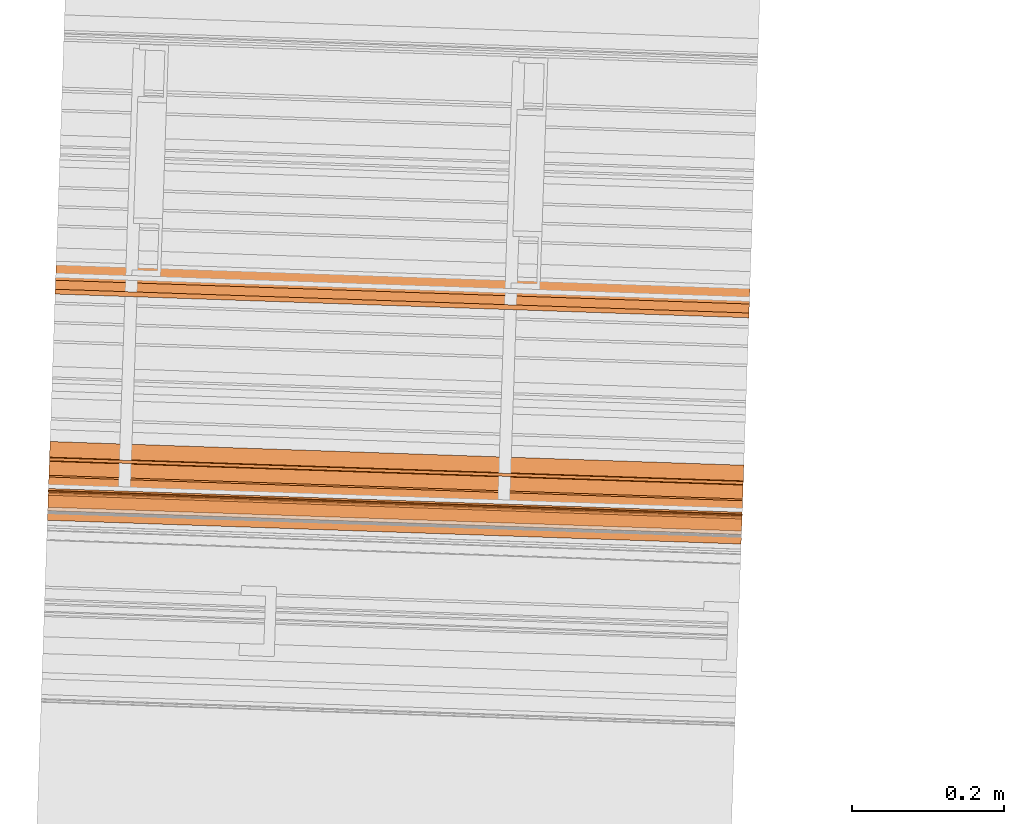
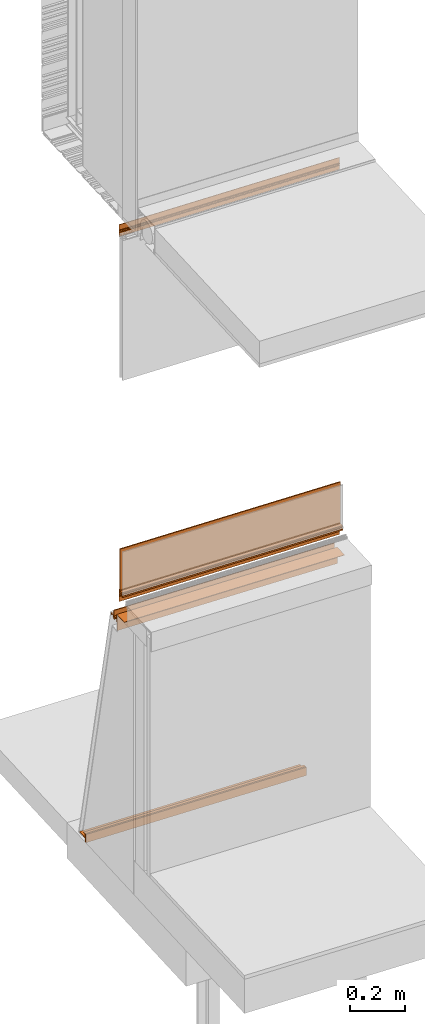
# One storey, part 11 of 36: 11 proxies.
"""IFC2X3 building model written with IfcOpenShell, lengths in feet."""

from ifc_helpers import new_model, entity, si_unit, converted_unit, derived_unit, direction, frame, frame_2d, origin, origin_2d_with_axis, place, context, subcontext, project, spatial, polyline, circle_curve, parameter, trimmed, segment, composite_curve, rectangle, outline, extrude, source, transform, mapped, material, type_object, type_shapes, element, save


model = new_model("IFC2X3")

# Units and contexts
model_context = context("Model", 3, precision=0.0001, world=origin(), true_north=direction((6.12303176911189e-17, 1.0)))
body_context = subcontext(model_context, "Body", "Model", "MODEL_VIEW")
ifc_project = project(units=[converted_unit("LENGTHUNIT", "FOOT", entity("IfcRatioMeasure", 0.3048), si_unit("LENGTHUNIT", "METRE"), dimensions=[1, 0, 0, 0, 0, 0, 0]), converted_unit("AREAUNIT", "SQUARE FOOT", entity("IfcRatioMeasure", 0.09290304), si_unit("AREAUNIT", "SQUARE_METRE"), dimensions=[2, 0, 0, 0, 0, 0, 0]), converted_unit("VOLUMEUNIT", "CUBIC FOOT", entity("IfcRatioMeasure", 0.028316846592), si_unit("VOLUMEUNIT", "CUBIC_METRE"), dimensions=[3, 0, 0, 0, 0, 0, 0]), converted_unit("PLANEANGLEUNIT", "DEGREE", entity("IfcRatioMeasure", 0.0174532925199433), si_unit("PLANEANGLEUNIT", "RADIAN"), dimensions=[0, 0, 0, 0, 0, 0, 0]), si_unit("MASSUNIT", "GRAM", prefix="KILO"), derived_unit("MASSDENSITYUNIT", [(si_unit("MASSUNIT", "GRAM", prefix="KILO"), 1), (si_unit("LENGTHUNIT", "METRE"), -3)]), si_unit("TIMEUNIT", "SECOND"), si_unit("FREQUENCYUNIT", "HERTZ"), si_unit("THERMODYNAMICTEMPERATUREUNIT", "DEGREE_CELSIUS"), derived_unit("THERMALTRANSMITTANCEUNIT", [(si_unit("MASSUNIT", "GRAM", prefix="KILO"), 1), (si_unit("THERMODYNAMICTEMPERATUREUNIT", "KELVIN"), -1), (si_unit("TIMEUNIT", "SECOND"), -3)]), derived_unit("VOLUMETRICFLOWRATEUNIT", [(si_unit("LENGTHUNIT", "METRE"), 3), (si_unit("TIMEUNIT", "SECOND"), -1)]), si_unit("ELECTRICCURRENTUNIT", "AMPERE"), si_unit("ELECTRICVOLTAGEUNIT", "VOLT"), si_unit("POWERUNIT", "WATT"), si_unit("FORCEUNIT", "NEWTON"), si_unit("ILLUMINANCEUNIT", "LUX"), si_unit("LUMINOUSFLUXUNIT", "LUMEN"), si_unit("LUMINOUSINTENSITYUNIT", "CANDELA"), derived_unit("USERDEFINED", [(si_unit("MASSUNIT", "GRAM", prefix="KILO"), -1), (si_unit("LENGTHUNIT", "METRE"), -2), (si_unit("TIMEUNIT", "SECOND"), 3), (si_unit("LUMINOUSFLUXUNIT", "LUMEN"), 1)]), derived_unit("LINEARVELOCITYUNIT", [(si_unit("LENGTHUNIT", "METRE"), 1), (si_unit("TIMEUNIT", "SECOND"), -1)]), si_unit("PRESSUREUNIT", "PASCAL"), derived_unit("USERDEFINED", [(si_unit("LENGTHUNIT", "METRE"), -2), (si_unit("MASSUNIT", "GRAM", prefix="KILO"), 1), (si_unit("TIMEUNIT", "SECOND"), -2)])], contexts=[model_context])

# Site, building, storey
site_placement = place(None, origin())
site = spatial("IfcSite", under=ifc_project, at=site_placement, CompositionType="ELEMENT")
building_placement = place(site_placement, origin())
building = spatial("IfcBuilding", under=site, at=building_placement, CompositionType="ELEMENT")
storey_placement = place(building_placement, origin())
storey = spatial("IfcBuildingStorey", under=building, at=storey_placement, Name="Level 1", CompositionType="ELEMENT", Elevation=0.0)

# Proxies
ifc_material_1 = material(Name="Window frame")
building_element_proxy_type_1 = type_object("IfcBuildingElementProxyType", Name="Window frame 016", PredefinedType="NOTDEFINED", material=ifc_material_1)
shared_shape_1 = source(origin(), body_context, "Body", "SweptSolid", [
    extrude(outline(composite_curve([segment(trimmed(circle_curve(frame_2d((0.0056011695834499, -0.0105069444443835), x_axis=(1.0, 0.0)), 0.00208333333333355), [parameter(359.999999999951)], [parameter(180.0)], True, "PARAMETER"), True, "CONTINUOUS"), segment(trimmed(circle_curve(frame_2d((0.00143450291648173, -0.0105069444443835), x_axis=(1.0, 0.0)), 0.00208333333333194), [parameter(270.0)], [parameter(0.0)], True, "PARAMETER"), False, "CONTINUOUS"), segment(polyline([(0.00143450291648124, -0.0125902777777149), (-0.00206549708348375, -0.0125902777778055)]), True, "CONTINUOUS"), segment(trimmed(circle_curve(frame_2d((-0.00206549708348375, -0.0105069444443835), x_axis=(1.0, 0.0)), 0.00208333333333249), [parameter(180.0)], [parameter(270.0)], True, "PARAMETER"), False, "CONTINUOUS"), segment(polyline([(-0.00414883041681443, -0.0105069444443835), (-0.00414883041661638, 0.00999305555562913)]), True, "CONTINUOUS"), segment(trimmed(circle_curve(frame_2d((-0.00206549708348454, 0.00999305555562913), x_axis=(1.0, 0.0)), 0.00208333333333313), [parameter(90.0000000000001)], [parameter(180.0)], True, "PARAMETER"), False, "CONTINUOUS"), segment(polyline([(-0.00206549708348405, 0.0120763888889623), (0.00143450291648094, 0.0120763888888593)]), True, "CONTINUOUS"), segment(trimmed(circle_curve(frame_2d((0.00143450291648094, 0.00999305555562913), x_axis=(1.0, 0.0)), 0.00208333333333237), [parameter(0.0)], [parameter(90.0000000000001)], True, "PARAMETER"), False, "CONTINUOUS"), segment(trimmed(circle_curve(frame_2d((0.00560116958344863, 0.00999305555562913), x_axis=(1.0, 0.0)), 0.00208333333333355), [parameter(180.0)], [parameter(0.0)], True, "PARAMETER"), True, "CONTINUOUS"), segment(polyline([(0.00768450291677979, 0.00999305555562913), (0.00768450291672444, 0.0146597222220013)]), True, "CONTINUOUS"), segment(trimmed(circle_curve(frame_2d((0.00510116958329547, 0.0146597222220013), x_axis=(1.0, 0.0)), 0.00258333333333234), [parameter(0.0)], [parameter(90.0000000000001)], True, "PARAMETER"), True, "CONTINUOUS"), segment(polyline([(0.00510116958329595, 0.0172430555553333), (-0.00231549708326447, 0.017243055555527)]), True, "CONTINUOUS"), segment(polyline([(-0.00231549708326447, 0.017243055555527), (-0.00231549708326215, 0.0755763888888605)]), True, "CONTINUOUS"), segment(polyline([(-0.00231549708326215, 0.0755763888888605), (-0.00748216374994208, 0.0755763888888605)]), True, "CONTINUOUS"), segment(polyline([(-0.00748216374994208, 0.0755763888888605), (-0.00748216374994111, 0.079743055555527)]), True, "CONTINUOUS"), segment(polyline([(-0.00748216374994111, 0.079743055555527), (-0.0108154970832782, 0.079743055555527)]), True, "CONTINUOUS"), segment(polyline([(-0.0108154970832782, 0.079743055555527), (-0.0108154970832785, -0.0973402777778052)]), True, "CONTINUOUS"), segment(polyline([(-0.0108154970832785, -0.0973402777778052), (-0.00306549708326241, -0.0973402777778052)]), True, "CONTINUOUS"), segment(polyline([(-0.00306549708326241, -0.0973402777778052), (-0.00414883041661713, -0.0921736111111375)]), True, "CONTINUOUS"), segment(polyline([(-0.00414883041661713, -0.0921736111111375), (-0.00414883041661802, -0.0192569444444715)]), True, "CONTINUOUS"), segment(polyline([(-0.00414883041661802, -0.0192569444444715), (0.00642309958338163, -0.0192569444444715)]), True, "CONTINUOUS"), segment(polyline([(0.00642309958338163, -0.0192569444444715), (0.0102678362500651, -0.0192569444444715)]), True, "CONTINUOUS"), segment(polyline([(0.0102678362500651, -0.0192569444444715), (0.010267836250067, -0.0125902777778055)]), True, "CONTINUOUS"), segment(polyline([(0.010267836250067, -0.0125902777778055), (0.00768450291678106, -0.0105069444443835)]), True, "CONTINUOUS")], self_intersect=False)), frame((109.718553820177, -50.5398433999572, 9.48804422127077), z_axis=(0.999414947916632, -0.0342017818365522, 0.0), x_axis=(-0.0342017818365522, -0.999414947916632, 0.0)), (0.0, 0.0, 1.0), 3.0),
])
type_shapes(building_element_proxy_type_1, [shared_shape_1])
proxy_1_placement = place(storey_placement, origin())
element("IfcBuildingElementProxy", 1, at=proxy_1_placement, inside=storey, type_object=building_element_proxy_type_1, material=ifc_material_1, Name="Window frame 016:Window frame 016", ObjectType="Window frame 016", context=body_context, shape_type="MappedRepresentation", body=[
    mapped(shared_shape_1, transform((0.0, 0.0, 0.0), scale=1.0)),
])
ifc_material_2 = material(Name="Clear glass")
building_element_proxy_type_2 = type_object("IfcBuildingElementProxyType", Name="Glass panel 007", PredefinedType="NOTDEFINED", material=ifc_material_2)
shared_shape_2 = source(origin(), body_context, "Body", "SweptSolid", [
    extrude(rectangle(XDim=3.0, YDim=0.0156250000000008, at=frame_2d((7.105427357601e-15, 2.42861286636753e-16), x_axis=(1.0, 0.0))), frame((111.217317225854, -50.6016369343463, 4.19540473523623), z_axis=(0.0, 0.0, 1.0), x_axis=(0.9994149479166, -0.0342017818375074, 0.0)), (0.0, 0.0, 1.0), 0.646205703051181),
])
type_shapes(building_element_proxy_type_2, [shared_shape_2])
proxy_2_placement = place(storey_placement, origin())
element("IfcBuildingElementProxy", 2, at=proxy_2_placement, inside=storey, type_object=building_element_proxy_type_2, material=ifc_material_2, Name="Glass panel 007:Glass panel 007", ObjectType="Glass panel 007", context=body_context, shape_type="MappedRepresentation", body=[
    mapped(shared_shape_2, transform((0.0, 0.0, 0.0), scale=1.0)),
])
building_element_proxy_type_3 = type_object("IfcBuildingElementProxyType", Name="Window frame part 042", PredefinedType="NOTDEFINED", material=ifc_material_1)
shared_shape_3 = source(origin(), body_context, "Body", "SweptSolid", [
    extrude(outline(polyline([(-0.00260416666666607, 0.0104166666666691), (0.0078125, 0.0104166666666691), (0.0078125, 0.0442500000000058), (-0.013020833333333, 0.0442500000000058), (-0.013020833333333, -0.0442499999999987), (0.0078125, -0.0442499999999987), (0.0078125, -0.010416666666662), (-0.00260416666666607, -0.010416666666662), (-0.00260416666666607, 0.0104166666666691)])), frame((109.717119585462, -50.5817533690172, 4.18238390190291), z_axis=(0.999414947916629, -0.0342017818366361, 0.0), x_axis=(0.0, 0.0, -1.0)), (0.0, 0.0, 1.0), 3.0),
])
type_shapes(building_element_proxy_type_3, [shared_shape_3])
proxy_3_placement = place(storey_placement, origin())
element("IfcBuildingElementProxy", 3, at=proxy_3_placement, inside=storey, type_object=building_element_proxy_type_3, material=ifc_material_1, Name="Window frame part 042:Window frame part 042", ObjectType="Window frame part 042", context=body_context, shape_type="MappedRepresentation", body=[
    mapped(shared_shape_3, transform((0.0, 0.0, 0.0), scale=1.0)),
])
ifc_material_3 = material(Name="Metallic support for window frame")
building_element_proxy_type_4 = type_object("IfcBuildingElementProxyType", Name="4mm panel 004", PredefinedType="NOTDEFINED", material=ifc_material_3)
shared_shape_4 = source(origin(), body_context, "Body", "SweptSolid", [
    extrude(rectangle(XDim=3.0, YDim=0.0130208333333268, at=origin_2d_with_axis()), frame((111.222373877749, -50.4538758172563, 3.73441666666667), z_axis=(0.0, 0.0, 1.0), x_axis=(0.999414947916692, -0.0342017818347979, 0.0)), (0.0, 0.0, 1.0), 0.118523384711286),
])
type_shapes(building_element_proxy_type_4, [shared_shape_4])
proxy_4_placement = place(storey_placement, origin())
element("IfcBuildingElementProxy", 4, at=proxy_4_placement, inside=storey, type_object=building_element_proxy_type_4, material=ifc_material_3, Name="4mm panel 004:4mm panel 004", ObjectType="4mm panel 004", context=body_context, shape_type="MappedRepresentation", body=[
    mapped(shared_shape_4, transform((0.0, 0.0, 0.0), scale=1.0)),
])
building_element_proxy_type_5 = type_object("IfcBuildingElementProxyType", Name="Window frame part 045", PredefinedType="NOTDEFINED", material=ifc_material_1)
shared_shape_5 = source(origin(), body_context, "Body", "SweptSolid", [
    extrude(rectangle(XDim=3.0, YDim=0.00500000000000083, at=frame_2d((-1.11022302462516e-16, 3.54924423184855e-15), x_axis=(1.0, 0.0))), frame((111.217669931729, -50.5913304677033, 4.21207140190289), z_axis=(0.0, 0.0, 1.0), x_axis=(0.999414947916767, -0.0342017818326165, 0.0)), (0.0, 0.0, 1.0), 0.020833333333333),
])
type_shapes(building_element_proxy_type_5, [shared_shape_5])
proxy_5_placement = place(storey_placement, origin())
element("IfcBuildingElementProxy", 5, at=proxy_5_placement, inside=storey, type_object=building_element_proxy_type_5, material=ifc_material_1, Name="Window frame part 045:Window frame part 045", ObjectType="Window frame part 045", context=body_context, shape_type="MappedRepresentation", body=[
    mapped(shared_shape_5, transform((0.0, 0.0, 0.0), scale=1.0)),
])
building_element_proxy_type_6 = type_object("IfcBuildingElementProxyType", Name="Metal profile 010", PredefinedType="NOTDEFINED", material=ifc_material_3)
shared_shape_6 = source(origin(), body_context, "Body", "SweptSolid", [
    extrude(outline(polyline([(-0.0641155348206457, -0.0806811023622043), (0.123064402974627, -0.0806811023622043), (0.123064402974627, -0.075514435695538), (-0.0589488681539805, -0.075514435695538), (-0.0589488681539805, 0.156195538057743), (-0.0641155348206457, 0.156195538057743), (-0.0641155348206457, -0.0806811023622043)])), frame((109.718431109704, -50.5434291396513, 3.75781889763779), z_axis=(0.999414947916631, -0.0342017818366047, 0.0), x_axis=(-0.0342017818366047, -0.999414947916631, 0.0)), (0.0, 0.0, 1.0), 3.0),
])
type_shapes(building_element_proxy_type_6, [shared_shape_6])
proxy_6_placement = place(storey_placement, origin())
element("IfcBuildingElementProxy", 6, at=proxy_6_placement, inside=storey, type_object=building_element_proxy_type_6, material=ifc_material_3, Name="Metal profile 010:Metal profile 010", ObjectType="Metal profile 010", context=body_context, shape_type="MappedRepresentation", body=[
    mapped(shared_shape_6, transform((0.0, 0.0, 0.0), scale=1.0)),
])
building_element_proxy_type_7 = type_object("IfcBuildingElementProxyType", Name="Window frame part 046", PredefinedType="NOTDEFINED", material=ifc_material_1)
shared_shape_7 = source(origin(), body_context, "Body", "SweptSolid", [
    extrude(outline(composite_curve([segment(trimmed(circle_curve(frame_2d((0.0, -0.11893368055565), x_axis=(1.0, 0.0)), 0.136017013888907), [parameter(78.9978270971846)], [parameter(101.002172902813)], True, "PARAMETER"), True, "CONTINUOUS"), segment(polyline([(-0.0259583333333445, 0.0145833333332561), (-0.0259583333333445, -0.0145833333332552)]), True, "CONTINUOUS"), segment(trimmed(circle_curve(frame_2d((0.0, 0.118933680555651), x_axis=(1.0, 0.0)), 0.136017013888907), [parameter(258.997827097187)], [parameter(281.002172902815)], True, "PARAMETER"), True, "CONTINUOUS"), segment(polyline([(0.0259583333333379, -0.0145833333332543), (0.0259583333333379, 0.0145833333332552)]), True, "CONTINUOUS")], self_intersect=False)), frame((109.717039781305, -50.5840853372298, 4.21998806856919), z_axis=(0.999414947916632, -0.0342017818365531, 0.0), x_axis=(-0.0342017818365531, -0.999414947916632, 0.0)), (0.0, 0.0, 1.0), 3.0),
])
type_shapes(building_element_proxy_type_7, [shared_shape_7])
proxy_7_placement = place(storey_placement, origin())
element("IfcBuildingElementProxy", 7, at=proxy_7_placement, inside=storey, type_object=building_element_proxy_type_7, material=ifc_material_1, Name="Window frame part 046:Window frame part 046", ObjectType="Window frame part 046", context=body_context, shape_type="MappedRepresentation", body=[
    mapped(shared_shape_7, transform((0.0, 0.0, 0.0), scale=1.0)),
])
building_element_proxy_type_8 = type_object("IfcBuildingElementProxyType", Name="support part 003", PredefinedType="NOTDEFINED", material=ifc_material_3)
shared_shape_8 = source(origin(), body_context, "Body", "SweptSolid", [
    extrude(outline(composite_curve([segment(trimmed(circle_curve(frame_2d((-0.00961538459791056, 0.027491985236062), x_axis=(0.0, -1.0)), 0.00520833335443878), [parameter(180.0)], [parameter(270.000000084861)], True, "PARAMETER"), True, "CONTINUOUS"), segment(polyline([(-0.0148237179523494, 0.0274919852283479), (-0.0148237179518431, 0.0196794852571455)]), True, "CONTINUOUS"), segment(polyline([(-0.0148237179518431, 0.0196794852571455), (-0.0226362179312858, 0.0196794852571455)]), True, "CONTINUOUS"), segment(trimmed(circle_curve(frame_2d((-0.0226362179312858, 0.0144711519049324), x_axis=(0.0, -1.0)), 0.00520833335443878), [parameter(180.0)], [parameter(270.000000084861)], True, "PARAMETER"), True, "CONTINUOUS"), segment(polyline([(-0.0278445512857246, 0.0144711518972183), (-0.0278445512851739, -0.0037580147281749)]), True, "CONTINUOUS"), segment(trimmed(circle_curve(frame_2d((-0.0226362179312858, -0.00375801472046079), x_axis=(0.0, -1.0)), 0.00520833335443146), [parameter(270.000000084861)], [parameter(0.0)], True, "PARAMETER"), True, "CONTINUOUS"), segment(polyline([(-0.0226362179312858, -0.00896634808260699), (-0.0148237179518431, -0.00896634807618677)]), True, "CONTINUOUS"), segment(polyline([(-0.0148237179518431, -0.00896634807618677), (-0.0148237179518409, -0.0167788480593187)]), True, "CONTINUOUS"), segment(trimmed(circle_curve(frame_2d((-0.00961538459791056, -0.0167788480516046), x_axis=(0.0, -1.0)), 0.00520833335443146), [parameter(270.000000084861)], [parameter(0.0)], True, "PARAMETER"), True, "CONTINUOUS"), segment(polyline([(-0.00961538459791056, -0.0219871814137579), (0.0138221153814904, -0.0219871814095273)]), True, "CONTINUOUS"), segment(polyline([(0.0138221153814904, -0.0219871814095273), (0.0138221153814904, -0.063966335576201)]), True, "CONTINUOUS"), segment(polyline([(0.0138221153814904, -0.063966335576201), (-0.0278445512851766, -0.063966335576201)]), True, "CONTINUOUS"), segment(polyline([(-0.0278445512851766, -0.063966335576201), (-0.0278445512851766, -0.0714663480761896)]), True, "CONTINUOUS"), segment(polyline([(-0.0278445512851766, -0.0714663480761896), (0.0763221153814904, -0.0714663480761896)]), True, "CONTINUOUS"), segment(polyline([(0.0763221153814904, -0.0714663480761896), (0.0763221153814904, -0.063966335576201)]), True, "CONTINUOUS"), segment(polyline([(0.0763221153814904, -0.063966335576201), (0.0216346153814904, -0.063966335576201)]), True, "CONTINUOUS"), segment(polyline([(0.0216346153814904, -0.063966335576201), (0.0216346153814904, -0.00375801474287024)]), True, "CONTINUOUS"), segment(polyline([(0.0216346153814904, -0.00375801474287024), (-0.0200320512851766, -0.00375801474287024)]), True, "CONTINUOUS"), segment(polyline([(-0.0200320512851766, -0.00375801474287024), (-0.0200320512851766, 0.014471151923801)]), True, "CONTINUOUS"), segment(polyline([(-0.0200320512851766, 0.014471151923801), (0.0216346153814904, 0.014471151923801)]), True, "CONTINUOUS"), segment(polyline([(0.0216346153814904, 0.014471151923801), (0.0216346153814904, 0.0821794852571483)]), True, "CONTINUOUS"), segment(polyline([(0.0216346153814904, 0.0821794852571483), (-0.00961538461850964, 0.0821794852571483)]), True, "CONTINUOUS"), segment(polyline([(-0.00961538461850964, 0.0821794852571483), (-0.00961538461850964, 0.074366985257138)]), True, "CONTINUOUS"), segment(polyline([(-0.00961538461850964, 0.074366985257138), (0.0138221153814904, 0.074366985257138)]), True, "CONTINUOUS"), segment(polyline([(0.0138221153814904, 0.074366985257138), (0.0138221153814904, 0.0327003185904723)]), True, "CONTINUOUS"), segment(polyline([(0.0138221153814904, 0.0327003185904723), (-0.00961538459791056, 0.0327003185904723)]), True, "CONTINUOUS")], self_intersect=False), holes=[polyline([(0.0138221153814904, 0.027652540801756), (0.0138221153814904, 0.0198400408017533), (-0.00961538461850964, 0.0198400408017533), (-0.00961538461850964, 0.027652540801756), (0.0138221153814904, 0.027652540801756)]), polyline([(-0.00961538461850964, -0.016618292531575), (-0.00961538461850964, -0.00880579253156475), (0.0138221153814904, -0.00880579253156475), (0.0138221153814904, -0.016618292531575), (-0.00961538461850964, -0.016618292531575)])]), frame((109.723068251684, -50.4079265792254, 3.75184455128517), z_axis=(-0.999414947916728, 0.0342017818337589, 0.0), x_axis=(0.0, 0.0, 1.0)), (0.0, 0.0, -1.0), 3.0),
])
type_shapes(building_element_proxy_type_8, [shared_shape_8])
proxy_8_placement = place(storey_placement, origin())
element("IfcBuildingElementProxy", 8, at=proxy_8_placement, inside=storey, type_object=building_element_proxy_type_8, material=ifc_material_3, Name="support part 003:support part 003", ObjectType="support part 003", context=body_context, shape_type="MappedRepresentation", body=[
    mapped(shared_shape_8, transform((0.0, 0.0, 0.0), scale=1.0)),
])
building_element_proxy_type_9 = type_object("IfcBuildingElementProxyType", Name="Metal profile 011", PredefinedType="NOTDEFINED", material=ifc_material_3)
shared_shape_9 = source(origin(), body_context, "Body", "SweptSolid", [
    extrude(rectangle(XDim=3.0, YDim=0.0208441399934384, at=frame_2d((-6.88338275267597e-15, -3.7921055184853e-15), x_axis=(1.0, 0.0))), frame((111.247158773605, -49.7296329833863, 0.0), z_axis=(0.0, 0.0, 1.0), x_axis=(0.999414947916638, -0.0342017818363966, 0.0)), (0.0, 0.0, 1.0), 0.121000083333339),
])
type_shapes(building_element_proxy_type_9, [shared_shape_9])
proxy_9_placement = place(storey_placement, origin())
element("IfcBuildingElementProxy", 9, at=proxy_9_placement, inside=storey, type_object=building_element_proxy_type_9, material=ifc_material_3, Name="Metal profile 011:Metal profile 011", ObjectType="Metal profile 011", context=body_context, shape_type="MappedRepresentation", body=[
    mapped(shared_shape_9, transform((0.0, 0.0, 0.0), scale=1.0)),
])
building_element_proxy_type_10 = type_object("IfcBuildingElementProxyType", Name="Window frame part 050", PredefinedType="NOTDEFINED", material=ifc_material_1)
shared_shape_10 = source(origin(), body_context, "Body", "SweptSolid", [
    extrude(outline(composite_curve([segment(polyline([(0.0125774774275781, 0.00335477699038478), (0.0158961953814152, 0.00335477699038478)]), True, "CONTINUOUS"), segment(polyline([(0.0158961953814152, 0.00335477699038478), (0.0200812117282686, 0.00854419724904718)]), True, "CONTINUOUS"), segment(polyline([(0.0200812117282686, 0.00854419724904718), (0.0170884181318157, 0.0109577404773129)]), True, "CONTINUOUS"), segment(polyline([(0.0170884181318157, 0.0109577404773129), (0.00885909041891168, 0.0175942950991215)]), True, "CONTINUOUS"), segment(polyline([(0.00885909041891168, 0.0175942950991215), (0.0546327067126372, 0.0743535791782271)]), True, "CONTINUOUS"), segment(polyline([(0.0546327067126372, 0.0743535791782271), (0.0587193751734874, 0.0776953147223203)]), True, "CONTINUOUS"), segment(polyline([(0.0587193751734874, 0.0776953147223203), (0.0526866741227865, 0.0825603962255443)]), True, "CONTINUOUS"), segment(polyline([(0.0526866741227865, 0.0825603962255443), (-0.0584778225905388, -0.0552835793951459)]), True, "CONTINUOUS"), segment(polyline([(-0.0584778225905388, -0.0552835793951459), (-0.0558831124611996, -0.0573760875685799)]), True, "CONTINUOUS"), segment(polyline([(-0.0558831124611996, -0.0573760875685799), (-0.0532674772444165, -0.0541326999069161)]), True, "CONTINUOUS"), segment(polyline([(-0.0532674772444165, -0.0541326999069161), (-0.0492456765439602, -0.0573760875757233)]), True, "CONTINUOUS"), segment(polyline([(-0.0492456765439602, -0.0573760875757233), (-0.0126267835089822, -0.0119686603124369)]), True, "CONTINUOUS"), segment(polyline([(-0.0126267835089822, -0.0119686603124369), (-0.00685355346654161, -0.0166244910023753)]), True, "CONTINUOUS"), segment(trimmed(circle_curve(frame_2d((-0.00523185963897295, -0.0146135906718913), x_axis=(0.778413038799201, -0.627752452028183)), 0.00258333333331436), [parameter(269.999999843105)], [parameter(4.35877971321483e-07)], True, "PARAMETER"), True, "CONTINUOUS"), segment(polyline([(-0.00322095928673516, -0.0162352844826684), (-0.000291447839006263, -0.0126026903050029)]), True, "CONTINUOUS"), segment(trimmed(circle_curve(frame_2d((-0.00191314167666622, -0.0112948727163502), x_axis=(0.778413038799201, -0.627752452028183)), 0.00208333333333281), [parameter(5.40464278134235e-07)], [parameter(179.999999459731)], True, "PARAMETER"), True, "CONTINUOUS"), segment(trimmed(circle_curve(frame_2d((-0.00515652934000852, -0.00867923749821213), x_axis=(0.778413038799201, -0.627752452028183)), 0.00208333333333701), [parameter(269.99999980545)], [parameter(5.40268864854606e-07)], True, "PARAMETER"), False, "CONTINUOUS"), segment(polyline([(-0.00646434694170673, -0.0103009313094754), (-0.00918879257618445, -0.00810379772817506)]), True, "CONTINUOUS"), segment(trimmed(circle_curve(frame_2d((-0.00788097497461577, -0.00648210391707316), x_axis=(0.778413038799201, -0.627752452028183)), 0.00208333333333701), [parameter(179.999999459731)], [parameter(269.99999980545)], True, "PARAMETER"), False, "CONTINUOUS"), segment(polyline([(-0.00950266880278239, -0.00517428628559347), (0.00336625646796169, 0.0107831810064475)]), True, "CONTINUOUS"), segment(trimmed(circle_curve(frame_2d((0.00498795029197169, 0.00947536337831994), x_axis=(0.778413038799201, -0.627752452028183)), 0.00208333333333701), [parameter(90.0000001945498)], [parameter(179.999999459731)], True, "PARAMETER"), False, "CONTINUOUS"), segment(polyline([(0.00629576790705163, 0.0110970572287142), (0.00902021354179903, 0.00889992364774747)]), True, "CONTINUOUS"), segment(trimmed(circle_curve(frame_2d((0.00771239592657933, 0.00727822979718067), x_axis=(0.778413038799201, -0.627752452028183)), 0.00208333333333676), [parameter(5.40268864854606e-07)], [parameter(90.0000001945498)], True, "PARAMETER"), False, "CONTINUOUS"), segment(trimmed(circle_curve(frame_2d((0.010955783589922, 0.00466259457904231), x_axis=(0.778413038799201, -0.627752452028183)), 0.0020833333333333), [parameter(179.999999459731)], [parameter(5.40342144834467e-07)], True, "PARAMETER"), True, "CONTINUOUS")], self_intersect=False)), frame((109.718553820183, -50.5398433999422, 4.1573283463301), z_axis=(0.999414947916556, -0.0342017818387831, 0.0), x_axis=(-0.0266231129294649, -0.777957626629212, -0.627752452028177)), (0.0, 0.0, 1.0), 3.00000000000001),
])
type_shapes(building_element_proxy_type_10, [shared_shape_10])
proxy_10_placement = place(storey_placement, origin())
element("IfcBuildingElementProxy", 10, at=proxy_10_placement, inside=storey, type_object=building_element_proxy_type_10, material=ifc_material_1, Name="Window frame part 050:Window frame part 050", ObjectType="Window frame part 050", context=body_context, shape_type="MappedRepresentation", body=[
    mapped(shared_shape_10, transform((0.0, 0.0, 0.0), scale=1.0)),
])
building_element_proxy_type_11 = type_object("IfcBuildingElementProxyType", Name="support part 004", PredefinedType="NOTDEFINED", material=ifc_material_3)
shared_shape_11 = source(origin(), body_context, "Body", "SweptSolid", [
    extrude(outline(polyline([(0.0450108251574815, 0.00150078083332532), (0.0502638434973765, 0.00150078083332532), (0.0502638434973765, 0.0402708950065429), (-0.0707368756627342, 0.0402708950065429), (-0.0707368756627342, 0.0327669916600929), (-0.0160210073228336, 0.0327669916600929), (-0.0160210073228336, -0.107305659160118), (-0.00851678566929026, -0.107305659160118), (-0.00851678566929026, 0.0327669916600929), (0.0450108251574815, 0.0327669916600929), (0.0450108251574815, 0.00150078083332532)])), frame((109.74977014146, -49.6276670036531, 0.0707368756627342), z_axis=(0.999414947916633, -0.0342017818365371, 0.0), x_axis=(0.0, 0.0, 1.0)), (0.0, 0.0, 1.0), 3.0),
])
type_shapes(building_element_proxy_type_11, [shared_shape_11])
proxy_11_placement = place(storey_placement, origin())
element("IfcBuildingElementProxy", 11, at=proxy_11_placement, inside=storey, type_object=building_element_proxy_type_11, material=ifc_material_3, Name="support part 004:support part 004", ObjectType="support part 004", context=body_context, shape_type="MappedRepresentation", body=[
    mapped(shared_shape_11, transform((0.0, 0.0, 0.0), scale=1.0)),
])

save(model, "model.ifc")
